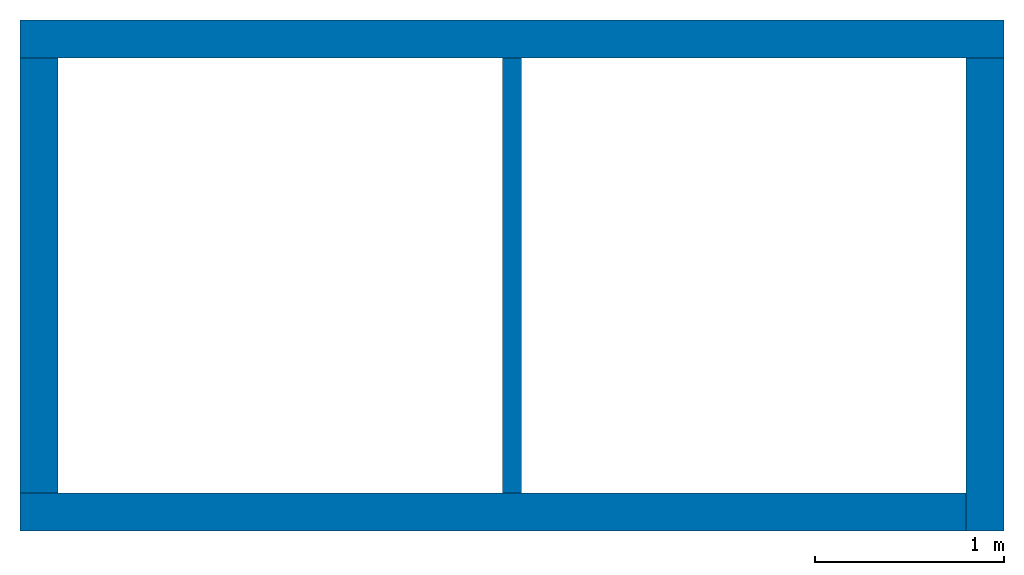
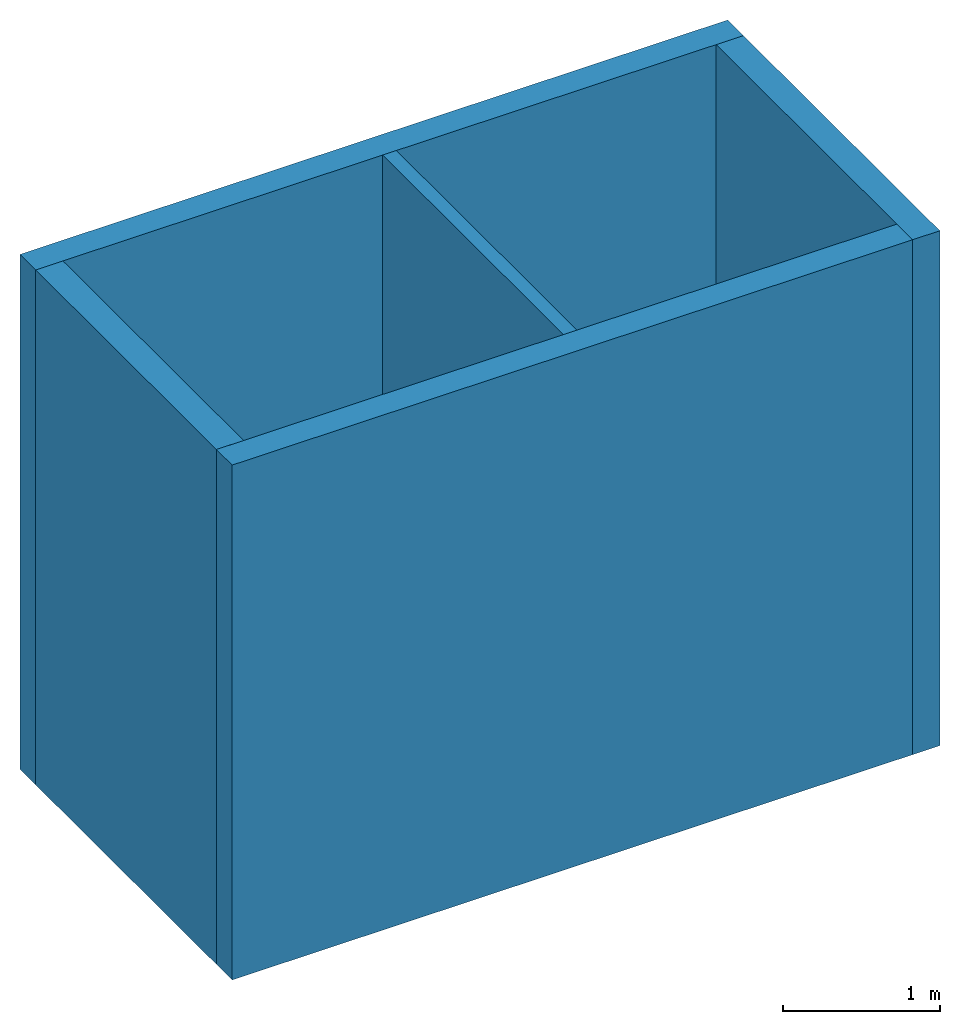
# One storey: 5 walls.
"""IFC4 building model written with IfcOpenShell, lengths in millimetres."""

from ifc_helpers import new_model, entity, si_unit, converted_unit, derived_unit, direction, frame, origin, place, context, subcontext, project, spatial, indexed_curve, outline, extrude, material, type_object, element, save


model = new_model("IFC4")

# Units and contexts
model_context = context("Model", 3, precision=0.01, world=origin(), true_north=direction((6.123031769111886e-17, 1.0)))
body_context = subcontext(model_context, "Body", "Model", "MODEL_VIEW")
ifc_project = project(units=[si_unit("LENGTHUNIT", "METRE", prefix="MILLI"), si_unit("AREAUNIT", "SQUARE_METRE"), si_unit("VOLUMEUNIT", "CUBIC_METRE"), converted_unit("PLANEANGLEUNIT", "DEGREE", entity("IfcPlaneAngleMeasure", 0.017453292519943278), si_unit("PLANEANGLEUNIT", "RADIAN"), dimensions=[0, 0, 0, 0, 0, 0, 0]), si_unit("MASSUNIT", "GRAM", prefix="KILO"), derived_unit("MASSDENSITYUNIT", [(si_unit("MASSUNIT", "GRAM", prefix="KILO"), 1), (si_unit("LENGTHUNIT", "METRE"), -3)]), derived_unit("IONCONCENTRATIONUNIT", [(si_unit("MASSUNIT", "GRAM", prefix="KILO"), 1), (si_unit("LENGTHUNIT", "METRE"), -3)]), derived_unit("MOMENTOFINERTIAUNIT", [(si_unit("LENGTHUNIT", "METRE"), 4)]), si_unit("TIMEUNIT", "SECOND"), si_unit("FREQUENCYUNIT", "HERTZ"), si_unit("THERMODYNAMICTEMPERATUREUNIT", "DEGREE_CELSIUS"), derived_unit("THERMALTRANSMITTANCEUNIT", [(si_unit("MASSUNIT", "GRAM", prefix="KILO"), 1), (si_unit("THERMODYNAMICTEMPERATUREUNIT", "KELVIN"), -1), (si_unit("TIMEUNIT", "SECOND"), -3)]), derived_unit("THERMALCONDUCTANCEUNIT", [(si_unit("MASSUNIT", "GRAM", prefix="KILO"), 1), (si_unit("THERMODYNAMICTEMPERATUREUNIT", "KELVIN"), -1), (si_unit("TIMEUNIT", "SECOND"), -3), (si_unit("LENGTHUNIT", "METRE"), 1)]), derived_unit("VOLUMETRICFLOWRATEUNIT", [(si_unit("LENGTHUNIT", "METRE", prefix="DECI"), 3), (si_unit("TIMEUNIT", "SECOND"), -1)]), derived_unit("MASSFLOWRATEUNIT", [(si_unit("MASSUNIT", "GRAM", prefix="KILO"), 1), (si_unit("TIMEUNIT", "SECOND"), -1)]), derived_unit("ROTATIONALFREQUENCYUNIT", [(si_unit("TIMEUNIT", "SECOND"), -1)]), si_unit("ELECTRICCURRENTUNIT", "AMPERE"), si_unit("ELECTRICVOLTAGEUNIT", "VOLT"), si_unit("POWERUNIT", "WATT"), si_unit("FORCEUNIT", "NEWTON", prefix="KILO"), si_unit("ILLUMINANCEUNIT", "LUX"), si_unit("LUMINOUSFLUXUNIT", "LUMEN"), si_unit("LUMINOUSINTENSITYUNIT", "CANDELA"), si_unit("ENERGYUNIT", "JOULE"), derived_unit("USERDEFINED", [(si_unit("MASSUNIT", "GRAM", prefix="KILO"), -1), (si_unit("LENGTHUNIT", "METRE"), -2), (si_unit("TIMEUNIT", "SECOND"), 3), (si_unit("LUMINOUSFLUXUNIT", "LUMEN"), 1)]), derived_unit("USERDEFINED", [(si_unit("MASSUNIT", "GRAM", prefix="KILO"), 1), (si_unit("TIMEUNIT", "SECOND"), -3), (si_unit("LENGTHUNIT", "METRE"), 3), (si_unit("ELECTRICCURRENTUNIT", "AMPERE"), -2)]), derived_unit("SOUNDPOWERUNIT", [(si_unit("MASSUNIT", "GRAM", prefix="KILO"), 1), (si_unit("TIMEUNIT", "SECOND"), -3), (si_unit("LENGTHUNIT", "METRE"), 2)]), derived_unit("SOUNDPRESSUREUNIT", [(si_unit("MASSUNIT", "GRAM", prefix="KILO"), 1), (si_unit("LENGTHUNIT", "METRE"), -1), (si_unit("TIMEUNIT", "SECOND"), -2)]), derived_unit("LINEARVELOCITYUNIT", [(si_unit("LENGTHUNIT", "METRE"), 1), (si_unit("TIMEUNIT", "SECOND"), -1)]), si_unit("PRESSUREUNIT", "PASCAL"), derived_unit("USERDEFINED", [(si_unit("MASSUNIT", "GRAM", prefix="KILO"), 1), (si_unit("LENGTHUNIT", "METRE"), -2), (si_unit("TIMEUNIT", "SECOND"), -2)]), derived_unit("LINEARFORCEUNIT", [(si_unit("MASSUNIT", "GRAM", prefix="KILO"), 1), (si_unit("TIMEUNIT", "SECOND"), -2)]), derived_unit("PLANARFORCEUNIT", [(si_unit("MASSUNIT", "GRAM", prefix="KILO"), 1), (si_unit("LENGTHUNIT", "METRE"), -1), (si_unit("TIMEUNIT", "SECOND"), -2)]), derived_unit("SPECIFICHEATCAPACITYUNIT", [(si_unit("THERMODYNAMICTEMPERATUREUNIT", "KELVIN"), -1), (si_unit("LENGTHUNIT", "METRE"), 2), (si_unit("TIMEUNIT", "SECOND"), -2)]), derived_unit("HEATFLUXDENSITYUNIT", [(si_unit("MASSUNIT", "GRAM", prefix="KILO"), 1), (si_unit("TIMEUNIT", "SECOND"), -3)]), derived_unit("HEATINGVALUEUNIT", [(si_unit("LENGTHUNIT", "METRE"), 2), (si_unit("TIMEUNIT", "SECOND"), -2)]), derived_unit("VAPORPERMEABILITYUNIT", [(si_unit("LENGTHUNIT", "METRE"), -1), (si_unit("TIMEUNIT", "SECOND"), 1)]), derived_unit("DYNAMICVISCOSITYUNIT", [(si_unit("MASSUNIT", "GRAM", prefix="KILO"), 1), (si_unit("TIMEUNIT", "SECOND"), -1), (si_unit("LENGTHUNIT", "METRE"), -1)]), derived_unit("THERMALEXPANSIONCOEFFICIENTUNIT", [(si_unit("THERMODYNAMICTEMPERATUREUNIT", "KELVIN"), -1)]), derived_unit("MODULUSOFELASTICITYUNIT", [(si_unit("MASSUNIT", "GRAM", prefix="KILO"), 1), (si_unit("LENGTHUNIT", "METRE"), -1), (si_unit("TIMEUNIT", "SECOND"), -2)]), derived_unit("ISOTHERMALMOISTURECAPACITYUNIT", [(si_unit("MASSUNIT", "GRAM", prefix="KILO"), -1), (si_unit("LENGTHUNIT", "METRE"), 3)]), derived_unit("MOISTUREDIFFUSIVITYUNIT", [(si_unit("TIMEUNIT", "SECOND"), -1), (si_unit("LENGTHUNIT", "METRE"), 2)]), derived_unit("AREADENSITYUNIT", [(si_unit("MASSUNIT", "GRAM", prefix="KILO"), 1), (si_unit("LENGTHUNIT", "METRE"), 2)]), derived_unit("MASSPERLENGTHUNIT", [(si_unit("MASSUNIT", "GRAM", prefix="KILO"), 1), (si_unit("LENGTHUNIT", "METRE"), -1)]), derived_unit("THERMALRESISTANCEUNIT", [(si_unit("MASSUNIT", "GRAM", prefix="KILO"), -1), (si_unit("TIMEUNIT", "SECOND"), 3), (si_unit("THERMODYNAMICTEMPERATUREUNIT", "KELVIN"), 1)]), derived_unit("ACCELERATIONUNIT", [(si_unit("LENGTHUNIT", "METRE"), 1), (si_unit("TIMEUNIT", "SECOND"), -2)]), derived_unit("ANGULARVELOCITYUNIT", [(si_unit("TIMEUNIT", "SECOND"), -1), (si_unit("PLANEANGLEUNIT", "RADIAN"), 1)]), derived_unit("LINEARSTIFFNESSUNIT", [(si_unit("MASSUNIT", "GRAM", prefix="KILO"), 1), (si_unit("TIMEUNIT", "SECOND"), -2)]), derived_unit("WARPINGCONSTANTUNIT", [(si_unit("LENGTHUNIT", "METRE"), 6)]), derived_unit("LINEARMOMENTUNIT", [(si_unit("MASSUNIT", "GRAM", prefix="KILO"), 1), (si_unit("LENGTHUNIT", "METRE"), 1), (si_unit("TIMEUNIT", "SECOND"), -2)]), derived_unit("TORQUEUNIT", [(si_unit("MASSUNIT", "GRAM", prefix="KILO"), 1), (si_unit("LENGTHUNIT", "METRE"), 2), (si_unit("TIMEUNIT", "SECOND"), -2)])], contexts=[model_context])

# Site, building, storey
site_placement = place(None, origin())
site = spatial("IfcSite", under=ifc_project, at=site_placement, CompositionType="ELEMENT")
building_placement = place(site_placement, origin())
building = spatial("IfcBuilding", under=site, at=building_placement, CompositionType="ELEMENT")
storey_placement = place(building_placement, origin())
storey = spatial("IfcBuildingStorey", under=building, at=storey_placement, Name="Level 1", CompositionType="ELEMENT", Elevation=0.0)

# Walls
ifc_material = material(Name="Default Wall")
wall_type_1 = type_object("IfcWallType", Name="Basic Wall:Wall 1", PredefinedType="STANDARD")
wall_1_placement = place(storey_placement, frame((1473.6873508353196, 3343.37708830549, 0.0)))
element("IfcWall", 1, at=wall_1_placement, inside=storey, type_object=wall_type_1, material=ifc_material, Name="Basic Wall:Wall 1:2984", ObjectType="Basic Wall:Wall 1", PredefinedType="NOTDEFINED", context=body_context, shape_type="SweptSolid", body=[
    extrude(outline(indexed_curve([(5200.000000000004, 99.99999999999955), (-5.3640177410438156e-14, 100.0), (5.3640177410438156e-14, -100.0), (5200.000000000004, -100.00000000000047), (5200.000000000004, 99.99999999999955)], self_intersect=False)), origin(), (0.0, 0.0, 1.0), 3999.9999999999995),
])
wall_2_placement = place(storey_placement, frame((6573.687350835321, 3243.377088305473, 0.0), z_axis=(0.0, 0.0, 1.0), x_axis=(0.0, -1.0, 0.0)))
element("IfcWall", 2, at=wall_2_placement, inside=storey, type_object=wall_type_1, material=ifc_material, Name="Basic Wall:Wall 1:3046", ObjectType="Basic Wall:Wall 1", PredefinedType="NOTDEFINED", context=body_context, shape_type="SweptSolid", body=[
    extrude(outline(indexed_curve([(2500.0, 100.0), (-2.1522985414118883e-14, 100.0), (2.1522985414118883e-14, -100.0), (2500.0, -100.0), (2500.0, 100.0)], self_intersect=False)), origin(), (0.0, 0.0, 1.0), 4000.0000000000005),
])
wall_3_placement = place(storey_placement, frame((6473.687350835309, 843.3770883054733, 0.0), z_axis=(0.0, 0.0, 1.0), x_axis=(-1.0, 0.0, 0.0)))
element("IfcWall", 3, at=wall_3_placement, inside=storey, type_object=wall_type_1, material=ifc_material, Name="Basic Wall:Wall 1:3164", ObjectType="Basic Wall:Wall 1", PredefinedType="NOTDEFINED", context=body_context, shape_type="SweptSolid", body=[
    extrude(outline(indexed_curve([(4999.999999999994, 100.0), (-3.221529709662723e-13, 100.0), (3.221529709662723e-13, -100.0), (4999.999999999994, -100.0), (4999.999999999994, 100.0)], self_intersect=False)), origin(), (0.0, 0.0, 1.0), 4000.0000000000005),
])
wall_4_placement = place(storey_placement, frame((1573.687350835316, 943.3770883054889, 0.0), z_axis=(0.0, 0.0, 1.0), x_axis=(0.0, 1.0, 0.0)))
element("IfcWall", 4, at=wall_4_placement, inside=storey, type_object=wall_type_1, material=ifc_material, Name="Basic Wall:Wall 1:3220", ObjectType="Basic Wall:Wall 1", PredefinedType="NOTDEFINED", context=body_context, shape_type="SweptSolid", body=[
    extrude(outline(indexed_curve([(2300.000000000001, 100.00000000000023), (-2.707167823245981e-14, 100.0), (2.707167823245981e-14, -100.0), (2300.000000000001, -99.99999999999979), (2300.000000000001, 100.00000000000023)], self_intersect=False)), origin(), (0.0, 0.0, 1.0), 3999.9999999999995),
])
wall_type_2 = type_object("IfcWallType", Name="Basic Wall:Wall 2", PredefinedType="STANDARD")
wall_5_placement = place(storey_placement, frame((4073.6873508353206, 3243.3770883054817, 0.0), z_axis=(0.0, 0.0, 1.0), x_axis=(0.0, -1.0, 0.0)))
element("IfcWall", 5, at=wall_5_placement, inside=storey, type_object=wall_type_2, material=ifc_material, Name="Basic Wall:Wall 2:3745", ObjectType="Basic Wall:Wall 2", PredefinedType="NOTDEFINED", context=body_context, shape_type="SweptSolid", body=[
    extrude(outline(indexed_curve([(2300.000000000001, 50.0), (-8.239206418574728e-14, 50.0), (8.239206418574728e-14, -50.0), (2300.000000000001, -50.0), (2300.000000000001, 50.0)], self_intersect=False)), origin(), (0.0, 0.0, 1.0), 3999.9999999999995),
])

save(model, "model.ifc")
